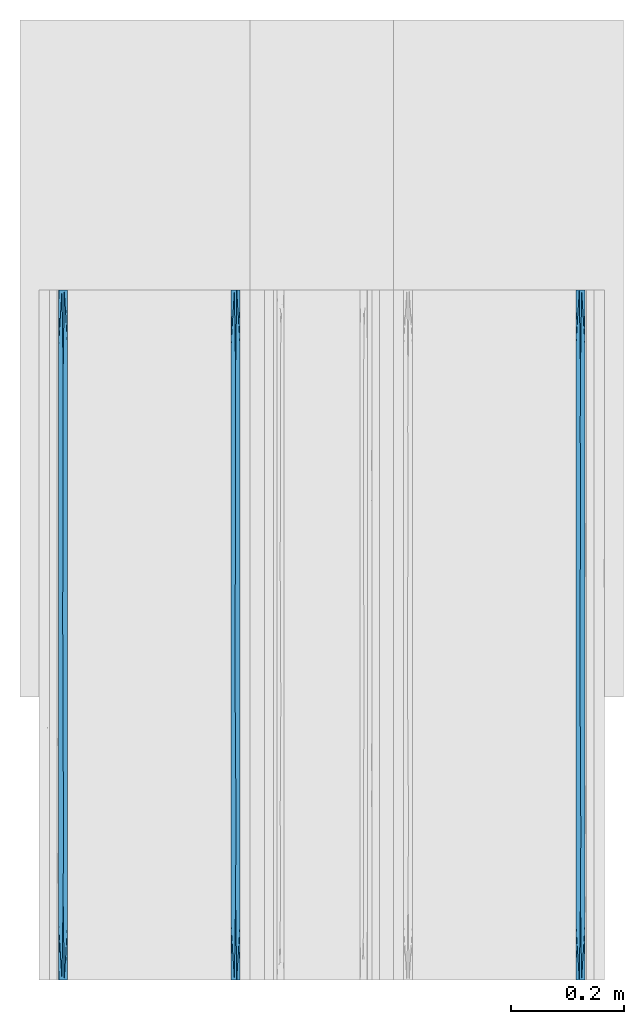
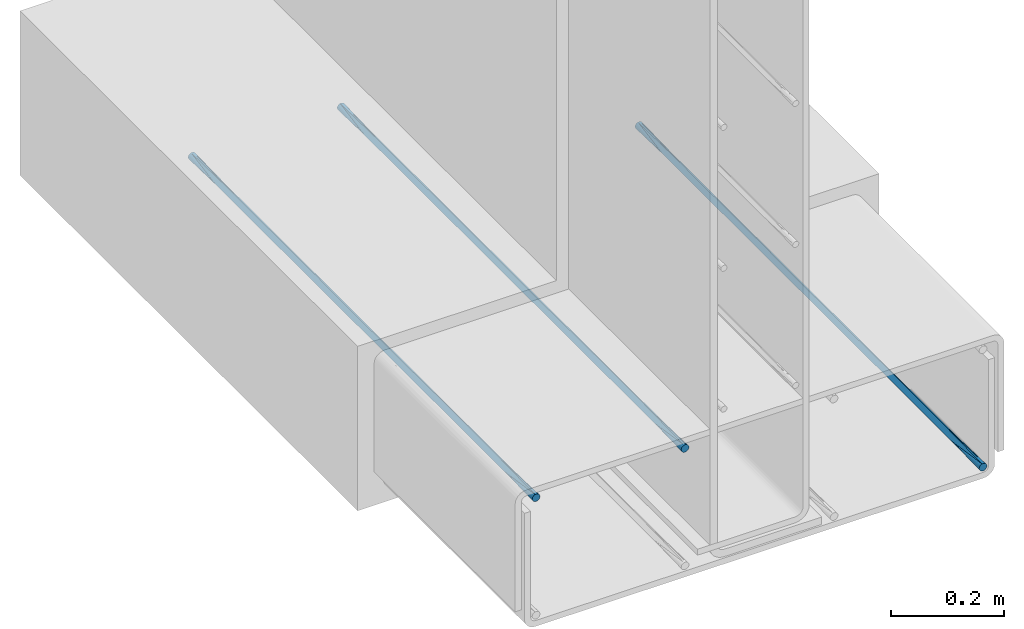
# One storey, part 6 of 10: 3 walls.
"""IFC2X3 building model written with IfcOpenShell, lengths in feet."""

from ifc_helpers import new_model, entity, si_unit, converted_unit, derived_unit, direction, frame, origin, place, context, subcontext, project, spatial, faceted_brep, material, type_object, element, save


model = new_model("IFC2X3")

# Units and contexts
model_context = context("Model", 3, precision=0.0001, world=origin(), true_north=direction((6.12303176911189e-17, 1.0)))
body_context = subcontext(model_context, "Body", "Model", "MODEL_VIEW")
ifc_project = project(units=[converted_unit("LENGTHUNIT", "FOOT", entity("IfcRatioMeasure", 0.3048), si_unit("LENGTHUNIT", "METRE"), dimensions=[1, 0, 0, 0, 0, 0, 0]), converted_unit("AREAUNIT", "SQUARE FOOT", entity("IfcRatioMeasure", 0.09290304), si_unit("AREAUNIT", "SQUARE_METRE"), dimensions=[2, 0, 0, 0, 0, 0, 0]), converted_unit("VOLUMEUNIT", "CUBIC FOOT", entity("IfcRatioMeasure", 0.028316846592), si_unit("VOLUMEUNIT", "CUBIC_METRE"), dimensions=[3, 0, 0, 0, 0, 0, 0]), converted_unit("PLANEANGLEUNIT", "DEGREE", entity("IfcRatioMeasure", 0.0174532925199433), si_unit("PLANEANGLEUNIT", "RADIAN"), dimensions=[0, 0, 0, 0, 0, 0, 0]), si_unit("MASSUNIT", "GRAM", prefix="KILO"), derived_unit("MASSDENSITYUNIT", [(si_unit("MASSUNIT", "GRAM", prefix="KILO"), 1), (si_unit("LENGTHUNIT", "METRE"), -3)]), si_unit("TIMEUNIT", "SECOND"), si_unit("FREQUENCYUNIT", "HERTZ"), si_unit("THERMODYNAMICTEMPERATUREUNIT", "DEGREE_CELSIUS"), derived_unit("THERMALTRANSMITTANCEUNIT", [(si_unit("MASSUNIT", "GRAM", prefix="KILO"), 1), (si_unit("THERMODYNAMICTEMPERATUREUNIT", "KELVIN"), -1), (si_unit("TIMEUNIT", "SECOND"), -3)]), derived_unit("VOLUMETRICFLOWRATEUNIT", [(si_unit("LENGTHUNIT", "METRE"), 3), (si_unit("TIMEUNIT", "SECOND"), -1)]), si_unit("ELECTRICCURRENTUNIT", "AMPERE"), si_unit("ELECTRICVOLTAGEUNIT", "VOLT"), si_unit("POWERUNIT", "WATT"), si_unit("FORCEUNIT", "NEWTON", prefix="KILO"), si_unit("ILLUMINANCEUNIT", "LUX"), si_unit("LUMINOUSFLUXUNIT", "LUMEN"), si_unit("LUMINOUSINTENSITYUNIT", "CANDELA"), derived_unit("USERDEFINED", [(si_unit("MASSUNIT", "GRAM", prefix="KILO"), -1), (si_unit("LENGTHUNIT", "METRE"), -2), (si_unit("TIMEUNIT", "SECOND"), 3), (si_unit("LUMINOUSFLUXUNIT", "LUMEN"), 1)]), derived_unit("LINEARVELOCITYUNIT", [(si_unit("LENGTHUNIT", "METRE"), 1), (si_unit("TIMEUNIT", "SECOND"), -1)]), si_unit("PRESSUREUNIT", "PASCAL"), derived_unit("USERDEFINED", [(si_unit("LENGTHUNIT", "METRE"), -2), (si_unit("MASSUNIT", "GRAM", prefix="KILO"), 1), (si_unit("TIMEUNIT", "SECOND"), -2)])], contexts=[model_context])

# Site, building, storey
site_placement = place(None, origin())
site = spatial("IfcSite", under=ifc_project, at=site_placement, CompositionType="ELEMENT")
building_placement = place(site_placement, origin())
building = spatial("IfcBuilding", under=site, at=building_placement, CompositionType="ELEMENT")
storey_placement = place(building_placement, frame((0.0, 0.0, 11.2604166666667)))
storey = spatial("IfcBuildingStorey", under=building, at=storey_placement, Name="2ND FLOOR", CompositionType="ELEMENT", Elevation=11.2604166666667)

# Walls
ifc_material = material()
wall_type_1 = type_object("IfcWallType", Name="Generic Models 1", PredefinedType="NOTDEFINED", material=ifc_material)
wall_1_placement = place(storey_placement, frame((1431.15274703322, 0.249999999995824, 2.87899174408174), z_axis=(0.0, 0.0, 1.0), x_axis=(0.0, 1.0, 0.0)))
element("IfcWall", 1, at=wall_1_placement, inside=storey, type_object=wall_type_1, material=ifc_material, Name="Generic Models 272:Generic Models 1", ObjectType="Generic Models 272:Generic Models 1", context=body_context, shape_type="Brep", body=[
    faceted_brep([(4.0, -0.0130208333334849, 0.0034889217764551), (4.0, -0.00762742757342494, 0.0076274275732775), (4.0, -0.00348892177657945, 0.0130208333333464), (4.0, -0.000887348273863608, 0.0193015873671367), (4.0, 0.0, 0.0260416666666821), (4.0, -0.000887348273863608, 0.0327817459662274), (4.0, -0.00348892177657945, 0.0390625000000142), (4.0, -0.00762742757342494, 0.0444559057600777), (4.0, -0.0130208333334849, 0.0485944115568948), (4.0, -0.0193015873671811, 0.0511959850596142), (4.0, -0.0260416666667425, 0.0520833333333321), (4.0, -0.0327817459663038, 0.0511959850596071), (4.0, -0.0390625, 0.048594411556877), (4.0, -0.04445590576006, 0.0444559057600546), (4.0, -0.0485944115569055, 0.0390624999999858), (4.0, -0.0511959850596213, 0.0327817459661954), (4.0, -0.0520833333334849, 0.0260416666666501), (4.0, -0.0511959850596213, 0.0193015873671047), (4.0, -0.0485944115569055, 0.0130208333333179), (4.0, -0.04445590576006, 0.00762742757325441), (4.0, -0.0390625, 0.00348892177643734), (4.0, -0.0327817459663038, 0.000887348273717947), (4.0, -0.0260416666667425, 0.0), (4.0, -0.0193015873671811, 0.000887348273725053), (0.0, -0.0260416666667425, 0.0520833333333393), (0.0, -0.0193015873671811, 0.0511959850596213), (0.0, -0.0130208333334849, 0.0485944115569019), (0.0, -0.00762742757342494, 0.0444559057600848), (0.0, -0.00348892177657945, 0.0390625000000213), (0.0, -0.000887348273863608, 0.0327817459662345), (0.0, 0.0, 0.0260416666666892), (0.0, -0.000887348273863608, 0.0193015873671438), (0.0, -0.00348892177657945, 0.0130208333333535), (0.0, -0.00762742757342494, 0.00762742757328461), (0.0, -0.0130208333334849, 0.00348892177646221), (0.0, -0.0193015873671811, 0.000887348273732158), (0.0, -0.0260416666667425, 0.0), (0.0, -0.0327817459663038, 0.000887348273725053), (0.0, -0.0390625, 0.00348892177644444), (0.0, -0.04445590576006, 0.00762742757326151), (0.0, -0.0485944115569055, 0.013020833333325), (0.0, -0.0511959850596213, 0.0193015873671119), (0.0, -0.0520833333334849, 0.0260416666666572), (0.0, -0.0511959850596213, 0.0327817459662025), (0.0, -0.0485944115569055, 0.0390624999999929), (0.0, -0.04445590576006, 0.0444559057600618), (0.0, -0.0390625, 0.0485944115568842), (0.0, -0.0327817459663038, 0.0511959850596142), (3.67725138549306, 0.0, 0.0260416666666821), (0.32274862547415, -0.0520833333334849, 0.0260416666666572), (3.67725140296933, -0.0520833333334849, 0.0260416666666501), (3.51587705267192, -0.0260416670323593, 0.0), (2.87037982919681, -0.0260416666374113, 0.0), (2.52958652603254, -0.026227183774381, 6.60807051744428e-07), (2.70900554197223, 0.0, 0.0260416666666838), (2.70900552654688, -0.0520833333334849, 0.0260416666666519), (1.90213399266994, -0.0280271573828941, 7.58000453888741e-05), (1.5, 0.0, 0.0260416666666874), (1.74075971428411, 0.0, 0.0260416666666874), (2.0, 0.0, 0.0260416666666856), (1.58481828942483, -0.0281065462752395, 8.19926513742075e-05), (2.35450277098611, 0.0, 0.0260416666666838), (2.38625689346174, 0.0, 0.0260416666666874), (0.322748614506943, 0.0, 0.0260416666666892), (0.484122917594275, -0.0260416666644687, 0.0), (0.645497229013885, 0.0, 0.0260416666666874), (3.03175415647917, 0.0, 0.0260416666666838), (3.35450277098611, 0.0, 0.0260416666666838), (0.802626606099821, -0.0241210785507064, 7.09188132521632e-05), (1.0, 0.0, 0.0260416666666874), (1.12499999124347, -0.0246126796300814, 3.92360336185504e-05), (3.35450277749518, -0.0520833333334849, 0.0260416666666519), (2.2160433903769, -0.0283845183157609, 0.000105602028249052), (2.06350830404206, -0.0520833333334849, 0.0260416666666519), (2.00000002040847, -0.0520833333334849, 0.0260416666666536), (1.74075970701139, -0.0520833333334849, 0.0260416666666536), (3.19312844079874, -0.0276322430397613, 4.86201045735157e-05), (3.03175415202103, -0.0520833333334849, 0.0260416666666519), (0.70900554076862, -0.0520833333334849, 0.0260416666666554), (0.645497257127644, -0.0520833333334849, 0.0260416666666554), (1.41801108153724, -0.0520833333334849, 0.0260416666666554), (1.25, 0.0, 0.0260416666666874), (1.41801107183056, 0.0, 0.0260416666666874), (2.38625690107273, -0.0520833333334849, 0.0260416666666554), (2.06350830387292, 0.0, 0.0260416666666856), (1.50000002551058, -0.0520833333334849, 0.0260416666666536), (1.25000002806164, -0.0520833333334849, 0.0260416666666554), (1.06350832537467, -0.0520833333334849, 0.0260416666666554), (1.06350827744056, 0.0, 0.0260416666666874), (1.0000000306127, -0.0520833333334849, 0.0260416666666554), (2.35450279389352, -0.0520833333334849, 0.0260416666666536), (0.70900553591528, 0.0, 0.0260416666666874), (1.90213399388276, -0.0240561759483171, 0.0520075332877745), (3.51587705385881, -0.0260416658200029, 0.0520833333333339), (2.87037983051048, -0.0260416667615573, 0.0520833333333339), (2.52958652644354, -0.0258561495911636, 0.0520826725265131), (0.484122917756005, -0.0260416666742458, 0.0520833333333393), (3.19312844116365, -0.0244510900004116, 0.0520347132108157), (1.58481829017475, -0.023976787102356, 0.0520013406854787), (1.12499999099503, -0.0274706537484235, 0.052044097297248), (0.802626606321884, -0.0279622548152929, 0.0520124145176908), (2.2160433912069, -0.023698814974523, 0.051977731301184)], [[[0, 1, 2, 3, 4, 5, 6, 7, 8, 9, 10, 11, 12, 13, 14, 15, 16, 17, 18, 19, 20, 21, 22, 23]], [[24, 25, 26, 27, 28, 29, 30, 31, 32, 33, 34, 35, 36, 37, 38, 39, 40, 41, 42, 43, 44, 45, 46, 47]], [[2, 48, 3]], [[49, 42, 41]], [[17, 16, 50]], [[20, 50, 21]], [[50, 51, 21]], [[40, 49, 41]], [[52, 53, 54]], [[52, 55, 53]], [[50, 19, 18]], [[56, 57, 58, 59]], [[38, 37, 49]], [[60, 57, 56]], [[0, 48, 1]], [[53, 61, 62, 54]], [[63, 32, 31]], [[64, 63, 65]], [[52, 54, 66]], [[48, 51, 67]], [[68, 69, 70]], [[23, 22, 51]], [[35, 64, 36]], [[2, 1, 48]], [[18, 17, 50]], [[19, 50, 20]], [[50, 71, 51]], [[56, 72, 73]], [[56, 73, 74, 75]], [[67, 51, 76]], [[55, 52, 77]], [[64, 78, 79, 49]], [[39, 38, 49]], [[0, 23, 48]], [[48, 23, 51]], [[60, 80, 70]], [[64, 65, 68]], [[37, 36, 64]], [[51, 22, 21]], [[60, 81, 82, 57]], [[40, 39, 49]], [[32, 63, 33]], [[77, 52, 76]], [[66, 67, 76]], [[34, 33, 63]], [[71, 77, 76]], [[35, 63, 64]], [[34, 63, 35]], [[48, 4, 3]], [[31, 30, 63]], [[53, 72, 61]], [[53, 83, 72]], [[64, 49, 37]], [[56, 75, 60]], [[72, 59, 84, 61]], [[60, 75, 85, 80]], [[70, 81, 60]], [[64, 68, 78]], [[70, 80, 86, 87]], [[70, 69, 88, 81]], [[68, 87, 89, 78]], [[72, 56, 59]], [[83, 53, 55]], [[72, 83, 90, 73]], [[76, 52, 66]], [[71, 76, 51]], [[68, 65, 91, 69]], [[87, 68, 70]], [[92, 84, 59, 58]], [[14, 50, 15]], [[8, 48, 9]], [[48, 93, 9]], [[28, 63, 29]], [[94, 95, 55]], [[44, 43, 49]], [[94, 54, 95]], [[47, 96, 24]], [[11, 10, 93]], [[5, 4, 48]], [[63, 30, 29]], [[66, 94, 97]], [[98, 85, 92]], [[12, 50, 13]], [[98, 86, 80, 85]], [[89, 99, 100]], [[49, 79, 96]], [[96, 91, 65, 63]], [[7, 48, 8]], [[48, 6, 5]], [[14, 13, 50]], [[48, 7, 6]], [[50, 93, 71]], [[48, 67, 93]], [[92, 101, 84]], [[12, 11, 50]], [[66, 54, 94]], [[95, 90, 83, 55]], [[27, 26, 63]], [[50, 11, 93]], [[96, 79, 100]], [[98, 82, 99]], [[92, 85, 75, 74]], [[24, 96, 25]], [[93, 10, 9]], [[97, 77, 71]], [[28, 27, 63]], [[44, 49, 45]], [[50, 16, 15]], [[43, 42, 49]], [[93, 97, 71]], [[46, 45, 49]], [[67, 66, 97]], [[47, 49, 96]], [[46, 49, 47]], [[26, 25, 63]], [[95, 101, 90]], [[95, 62, 101]], [[96, 63, 25]], [[92, 58, 98]], [[101, 74, 73, 90]], [[98, 58, 57, 82]], [[99, 86, 98]], [[96, 100, 91]], [[99, 82, 81, 88]], [[99, 89, 87, 86]], [[100, 88, 69, 91]], [[101, 92, 74]], [[94, 55, 77]], [[62, 95, 54]], [[101, 62, 61, 84]], [[97, 94, 77]], [[67, 97, 93]], [[100, 79, 78, 89]], [[88, 100, 99]]]),
])
wall_type_2 = type_object("IfcWallType", Name="Generic Models 1", PredefinedType="NOTDEFINED", material=ifc_material)
wall_2_placement = place(storey_placement, frame((1428.15274703322, 0.249999999995834, 3.71232507741509), z_axis=(0.0, 0.0, 1.0), x_axis=(0.0, 1.0, 0.0)))
element("IfcWall", 2, at=wall_2_placement, inside=storey, type_object=wall_type_2, material=ifc_material, Name="Generic Models 54:Generic Models 1", ObjectType="Generic Models 54:Generic Models 1", context=body_context, shape_type="Brep", body=[
    faceted_brep([(4.0, -0.0130208333334849, 0.0034889217764551), (4.0, -0.00762742757342494, 0.0076274275732775), (4.0, -0.00348892177657945, 0.0130208333333464), (4.0, -0.000887348273863608, 0.0193015873671367), (4.0, 0.0, 0.0260416666666821), (4.0, -0.000887348273863608, 0.0327817459662274), (4.0, -0.00348892177657945, 0.0390625000000142), (4.0, -0.00762742757342494, 0.0444559057600777), (4.0, -0.0130208333334849, 0.0485944115568948), (4.0, -0.0193015873671811, 0.0511959850596142), (4.0, -0.0260416666667425, 0.0520833333333321), (4.0, -0.0327817459663038, 0.0511959850596071), (4.0, -0.0390625, 0.048594411556877), (4.0, -0.04445590576006, 0.0444559057600546), (4.0, -0.0485944115569055, 0.0390624999999858), (4.0, -0.0511959850596213, 0.0327817459661954), (4.0, -0.0520833333334849, 0.0260416666666501), (4.0, -0.0511959850596213, 0.0193015873671047), (4.0, -0.0485944115569055, 0.0130208333333179), (4.0, -0.04445590576006, 0.00762742757325441), (4.0, -0.0390625, 0.00348892177643734), (4.0, -0.0327817459663038, 0.000887348273717947), (4.0, -0.0260416666667425, 0.0), (4.0, -0.0193015873671811, 0.000887348273725053), (0.0, -0.0260416666667425, 0.0520833333333393), (0.0, -0.0193015873671811, 0.0511959850596213), (0.0, -0.0130208333334849, 0.0485944115569019), (0.0, -0.00762742757342494, 0.0444559057600848), (0.0, -0.00348892177657945, 0.0390625000000213), (0.0, -0.000887348273863608, 0.0327817459662345), (0.0, 0.0, 0.0260416666666892), (0.0, -0.000887348273863608, 0.0193015873671438), (0.0, -0.00348892177657945, 0.0130208333333535), (0.0, -0.00762742757342494, 0.00762742757328461), (0.0, -0.0130208333334849, 0.00348892177646221), (0.0, -0.0193015873671811, 0.000887348273732158), (0.0, -0.0260416666667425, 0.0), (0.0, -0.0327817459663038, 0.000887348273725053), (0.0, -0.0390625, 0.00348892177644444), (0.0, -0.04445590576006, 0.00762742757326151), (0.0, -0.0485944115569055, 0.013020833333325), (0.0, -0.0511959850596213, 0.0193015873671119), (0.0, -0.0520833333334849, 0.0260416666666572), (0.0, -0.0511959850596213, 0.0327817459662025), (0.0, -0.0485944115569055, 0.0390624999999929), (0.0, -0.04445590576006, 0.0444559057600618), (0.0, -0.0390625, 0.0485944115568842), (0.0, -0.0327817459663038, 0.0511959850596142), (3.67725138549306, 0.0, 0.0260416666666821), (0.32274862547415, -0.0520833333334849, 0.0260416666666554), (3.67725140296933, -0.0520833333334849, 0.0260416666666501), (3.51587705267192, -0.0260416670323593, 0.0), (2.87037982919681, -0.0260416666374113, 0.0), (2.52958652603254, -0.026227183774381, 6.60807051744428e-07), (2.70900554197223, 0.0, 0.0260416666666838), (2.70900552654688, -0.0520833333334849, 0.0260416666666519), (1.90213399266994, -0.0280271573828941, 7.58000453888741e-05), (1.5, 0.0, 0.0260416666666874), (1.74075971428411, 0.0, 0.0260416666666874), (2.0, 0.0, 0.0260416666666856), (1.58481828942483, -0.0281065462752395, 8.19926513742075e-05), (2.35450277098611, 0.0, 0.0260416666666838), (2.38625689346174, 0.0, 0.0260416666666856), (0.322748614506943, 0.0, 0.0260416666666892), (0.484122917594275, -0.0260416666644687, 0.0), (0.645497229013885, 0.0, 0.0260416666666874), (3.03175415647917, 0.0, 0.0260416666666838), (3.35450277098611, 0.0, 0.0260416666666838), (0.802626606099821, -0.0241210785507064, 7.09188132521632e-05), (1.0, 0.0, 0.0260416666666874), (1.12499999124347, -0.0246126796300814, 3.92360336185504e-05), (3.35450277749518, -0.0520833333334849, 0.0260416666666501), (2.2160433903769, -0.0283845183157609, 0.000105602028249052), (2.06350830404206, -0.0520833333334849, 0.0260416666666536), (2.00000002040847, -0.0520833333334849, 0.0260416666666536), (1.74075970701139, -0.0520833333334849, 0.0260416666666536), (3.19312844079874, -0.0276322430397613, 4.86201045735157e-05), (3.03175415202103, -0.0520833333334849, 0.0260416666666519), (0.70900554076862, -0.0520833333334849, 0.0260416666666572), (0.645497257127644, -0.0520833333332575, 0.0260416666666554), (1.41801108153724, -0.0520833333334849, 0.0260416666666554), (1.25, 0.0, 0.0260416666666874), (1.41801107183056, 0.0, 0.0260416666666874), (2.38625690107273, -0.0520833333334849, 0.0260416666666554), (2.06350830387292, 0.0, 0.0260416666666856), (1.50000002551058, -0.0520833333334849, 0.0260416666666536), (1.25000002806164, -0.0520833333334849, 0.0260416666666554), (1.06350832537467, -0.0520833333334849, 0.0260416666666554), (1.06350827744056, 0.0, 0.0260416666666874), (1.0000000306127, -0.0520833333334849, 0.0260416666666554), (2.35450279389352, -0.0520833333334849, 0.0260416666666536), (0.70900553591528, 0.0, 0.0260416666666892), (1.90213399388276, -0.0240561759483171, 0.0520075332877745), (3.51587705385881, -0.0260416658200029, 0.0520833333333339), (2.87037983051048, -0.0260416667615573, 0.0520833333333339), (2.52958652644354, -0.0258561495911636, 0.0520826725265131), (0.484122917756005, -0.0260416666742458, 0.0520833333333393), (3.19312844116365, -0.0244510900004116, 0.0520347132108157), (1.58481829017475, -0.023976787102356, 0.0520013406854787), (1.12499999099503, -0.0274706537484235, 0.052044097297248), (0.802626606321884, -0.0279622548152929, 0.0520124145176908), (2.2160433912069, -0.023698814974523, 0.051977731301184)], [[[0, 1, 2, 3, 4, 5, 6, 7, 8, 9, 10, 11, 12, 13, 14, 15, 16, 17, 18, 19, 20, 21, 22, 23]], [[24, 25, 26, 27, 28, 29, 30, 31, 32, 33, 34, 35, 36, 37, 38, 39, 40, 41, 42, 43, 44, 45, 46, 47]], [[2, 48, 3]], [[49, 42, 41]], [[17, 16, 50]], [[20, 50, 21]], [[50, 51, 21]], [[40, 49, 41]], [[52, 53, 54]], [[52, 55, 53]], [[50, 19, 18]], [[56, 57, 58, 59]], [[38, 37, 49]], [[60, 57, 56]], [[0, 48, 1]], [[53, 61, 62, 54]], [[63, 32, 31]], [[64, 63, 65]], [[52, 54, 66]], [[48, 51, 67]], [[68, 69, 70]], [[23, 22, 51]], [[35, 64, 36]], [[2, 1, 48]], [[18, 17, 50]], [[19, 50, 20]], [[50, 71, 51]], [[56, 72, 73]], [[56, 73, 74, 75]], [[67, 51, 76]], [[55, 52, 77]], [[64, 78, 79, 49]], [[39, 38, 49]], [[0, 23, 48]], [[48, 23, 51]], [[60, 80, 70]], [[64, 65, 68]], [[37, 36, 64]], [[51, 22, 21]], [[60, 81, 82, 57]], [[40, 39, 49]], [[32, 63, 33]], [[77, 52, 76]], [[66, 67, 76]], [[34, 33, 63]], [[71, 77, 76]], [[35, 63, 64]], [[34, 63, 35]], [[48, 4, 3]], [[31, 30, 63]], [[53, 72, 61]], [[53, 83, 72]], [[64, 49, 37]], [[56, 75, 60]], [[72, 59, 84, 61]], [[60, 75, 85, 80]], [[70, 81, 60]], [[64, 68, 78]], [[70, 80, 86, 87]], [[70, 69, 88, 81]], [[68, 87, 89, 78]], [[72, 56, 59]], [[83, 53, 55]], [[72, 83, 90, 73]], [[76, 52, 66]], [[71, 76, 51]], [[68, 65, 91, 69]], [[87, 68, 70]], [[92, 84, 59, 58]], [[14, 50, 15]], [[8, 48, 9]], [[48, 93, 9]], [[28, 63, 29]], [[94, 95, 55]], [[44, 43, 49]], [[94, 54, 95]], [[47, 96, 24]], [[11, 10, 93]], [[5, 4, 48]], [[63, 30, 29]], [[66, 94, 97]], [[98, 85, 92]], [[12, 50, 13]], [[98, 86, 80, 85]], [[89, 99, 100]], [[49, 79, 96]], [[96, 91, 65, 63]], [[7, 48, 8]], [[48, 6, 5]], [[14, 13, 50]], [[48, 7, 6]], [[50, 93, 71]], [[48, 67, 93]], [[92, 101, 84]], [[12, 11, 50]], [[66, 54, 94]], [[95, 90, 83, 55]], [[27, 26, 63]], [[50, 11, 93]], [[96, 79, 100]], [[98, 82, 99]], [[92, 85, 75, 74]], [[24, 96, 25]], [[93, 10, 9]], [[97, 77, 71]], [[28, 27, 63]], [[44, 49, 45]], [[50, 16, 15]], [[43, 42, 49]], [[93, 97, 71]], [[46, 45, 49]], [[67, 66, 97]], [[47, 49, 96]], [[46, 49, 47]], [[26, 25, 63]], [[95, 101, 90]], [[95, 62, 101]], [[96, 63, 25]], [[92, 58, 98]], [[101, 74, 73, 90]], [[98, 58, 57, 82]], [[99, 86, 98]], [[96, 100, 91]], [[99, 82, 81, 88]], [[99, 89, 87, 86]], [[100, 88, 69, 91]], [[101, 92, 74]], [[94, 55, 77]], [[62, 95, 54]], [[101, 62, 61, 84]], [[97, 94, 77]], [[67, 97, 93]], [[100, 79, 78, 89]], [[88, 100, 99]]]),
])
wall_type_3 = type_object("IfcWallType", Name="Generic Models 1", PredefinedType="NOTDEFINED", material=ifc_material)
wall_3_placement = place(storey_placement, frame((1429.15274703322, 0.24999999999583, 3.71232507741509), z_axis=(0.0, 0.0, 1.0), x_axis=(0.0, 1.0, 0.0)))
element("IfcWall", 3, at=wall_3_placement, inside=storey, type_object=wall_type_3, material=ifc_material, Name="Generic Models 67:Generic Models 1", ObjectType="Generic Models 67:Generic Models 1", context=body_context, shape_type="Brep", body=[
    faceted_brep([(4.0, -0.0130208333334849, 0.0034889217764551), (4.0, -0.00762742757342494, 0.0076274275732775), (4.0, -0.00348892177657945, 0.0130208333333464), (4.0, -0.000887348273863608, 0.0193015873671367), (4.0, 0.0, 0.0260416666666821), (4.0, -0.000887348273863608, 0.0327817459662274), (4.0, -0.00348892177657945, 0.0390625000000142), (4.0, -0.00762742757342494, 0.0444559057600777), (4.0, -0.0130208333334849, 0.0485944115568948), (4.0, -0.0193015873671811, 0.0511959850596142), (4.0, -0.0260416666667425, 0.0520833333333321), (4.0, -0.0327817459663038, 0.0511959850596071), (4.0, -0.0390625, 0.048594411556877), (4.0, -0.04445590576006, 0.0444559057600546), (4.0, -0.0485944115569055, 0.0390624999999858), (4.0, -0.0511959850596213, 0.0327817459661954), (4.0, -0.0520833333334849, 0.0260416666666501), (4.0, -0.0511959850596213, 0.0193015873671047), (4.0, -0.0485944115569055, 0.0130208333333179), (4.0, -0.04445590576006, 0.00762742757325441), (4.0, -0.0390625, 0.00348892177643734), (4.0, -0.0327817459663038, 0.000887348273717947), (4.0, -0.0260416666667425, 0.0), (4.0, -0.0193015873671811, 0.000887348273725053), (0.0, -0.0260416666667425, 0.0520833333333393), (0.0, -0.0193015873671811, 0.0511959850596213), (0.0, -0.0130208333334849, 0.0485944115569019), (0.0, -0.00762742757342494, 0.0444559057600848), (0.0, -0.00348892177657945, 0.0390625000000213), (0.0, -0.000887348273863608, 0.0327817459662345), (0.0, 0.0, 0.0260416666666892), (0.0, -0.000887348273863608, 0.0193015873671438), (0.0, -0.00348892177657945, 0.0130208333333535), (0.0, -0.00762742757342494, 0.00762742757328461), (0.0, -0.0130208333334849, 0.00348892177646221), (0.0, -0.0193015873671811, 0.000887348273732158), (0.0, -0.0260416666667425, 0.0), (0.0, -0.0327817459663038, 0.000887348273725053), (0.0, -0.0390625, 0.00348892177644444), (0.0, -0.04445590576006, 0.00762742757326151), (0.0, -0.0485944115569055, 0.013020833333325), (0.0, -0.0511959850596213, 0.0193015873671119), (0.0, -0.0520833333334849, 0.0260416666666572), (0.0, -0.0511959850596213, 0.0327817459662025), (0.0, -0.0485944115569055, 0.0390624999999929), (0.0, -0.04445590576006, 0.0444559057600618), (0.0, -0.0390625, 0.0485944115568842), (0.0, -0.0327817459663038, 0.0511959850596142), (3.67725138549306, 0.0, 0.0260416666666821), (0.32274862547415, -0.0520833333334849, 0.0260416666666572), (3.67725140296933, -0.0520833333332575, 0.0260416666666501), (3.51587705267192, -0.0260416670323593, 0.0), (2.87037982919681, -0.0260416666374113, 0.0), (2.52958652603254, -0.026227183774381, 6.60807051744428e-07), (2.70900554197223, 0.0, 0.0260416666666838), (2.70900552654688, -0.0520833333334849, 0.0260416666666536), (1.90213399266994, -0.0280271573828941, 7.58000453888741e-05), (1.5, 0.0, 0.0260416666666874), (1.74075971428411, 0.0, 0.0260416666666856), (2.0, 0.0, 0.0260416666666856), (1.58481828942483, -0.0281065462752395, 8.19926513742075e-05), (2.35450277098611, 0.0, 0.0260416666666838), (2.38625689346174, 0.0, 0.0260416666666874), (0.322748614506943, 0.0, 0.0260416666666892), (0.484122917594275, -0.0260416666644687, 0.0), (0.645497229013885, 0.0, 0.0260416666666874), (3.03175415647917, 0.0, 0.0260416666666838), (3.35450277098611, 0.0, 0.0260416666666838), (0.802626606099821, -0.0241210785507064, 7.09188132521632e-05), (1.0, 0.0, 0.0260416666666874), (1.12499999124347, -0.0246126796300814, 3.92360336185504e-05), (3.35450277749518, -0.0520833333334849, 0.0260416666666519), (2.2160433903769, -0.0283845183157609, 0.000105602028249052), (2.06350830404206, -0.0520833333334849, 0.0260416666666536), (2.00000002040847, -0.0520833333334849, 0.0260416666666536), (1.74075970701139, -0.0520833333334849, 0.0260416666666536), (3.19312844079874, -0.0276322430397613, 4.86201045735157e-05), (3.03175415202103, -0.0520833333334849, 0.0260416666666519), (0.70900554076862, -0.0520833333334849, 0.0260416666666554), (0.645497257127644, -0.0520833333334849, 0.0260416666666554), (1.41801108153724, -0.0520833333334849, 0.0260416666666554), (1.25, 0.0, 0.0260416666666874), (1.41801107183056, 0.0, 0.0260416666666874), (2.38625690107273, -0.0520833333334849, 0.0260416666666519), (2.06350830387292, 0.0, 0.0260416666666856), (1.50000002551058, -0.0520833333334849, 0.0260416666666519), (1.25000002806164, -0.0520833333334849, 0.0260416666666554), (1.06350832537467, -0.0520833333334849, 0.0260416666666554), (1.06350827744056, 0.0, 0.0260416666666874), (1.0000000306127, -0.0520833333334849, 0.0260416666666554), (2.35450279389352, -0.0520833333334849, 0.0260416666666519), (0.70900553591528, 0.0, 0.0260416666666874), (1.90213399388276, -0.0240561759483171, 0.0520075332877745), (3.51587705385881, -0.0260416658200029, 0.0520833333333339), (2.87037983051048, -0.0260416667615573, 0.0520833333333339), (2.52958652644354, -0.0258561495911636, 0.0520826725265131), (0.484122917756005, -0.0260416666742458, 0.0520833333333393), (3.19312844116365, -0.0244510900004116, 0.0520347132108157), (1.58481829017475, -0.023976787102356, 0.0520013406854787), (1.12499999099503, -0.0274706537484235, 0.052044097297248), (0.802626606321884, -0.0279622548152929, 0.0520124145176908), (2.2160433912069, -0.023698814974523, 0.051977731301184)], [[[0, 1, 2, 3, 4, 5, 6, 7, 8, 9, 10, 11, 12, 13, 14, 15, 16, 17, 18, 19, 20, 21, 22, 23]], [[24, 25, 26, 27, 28, 29, 30, 31, 32, 33, 34, 35, 36, 37, 38, 39, 40, 41, 42, 43, 44, 45, 46, 47]], [[2, 48, 3]], [[49, 42, 41]], [[17, 16, 50]], [[20, 50, 21]], [[50, 51, 21]], [[40, 49, 41]], [[52, 53, 54]], [[52, 55, 53]], [[50, 19, 18]], [[56, 57, 58, 59]], [[38, 37, 49]], [[60, 57, 56]], [[0, 48, 1]], [[53, 61, 62, 54]], [[63, 32, 31]], [[64, 63, 65]], [[52, 54, 66]], [[48, 51, 67]], [[68, 69, 70]], [[23, 22, 51]], [[35, 64, 36]], [[2, 1, 48]], [[18, 17, 50]], [[19, 50, 20]], [[50, 71, 51]], [[56, 72, 73]], [[56, 73, 74, 75]], [[67, 51, 76]], [[55, 52, 77]], [[64, 78, 79, 49]], [[39, 38, 49]], [[0, 23, 48]], [[48, 23, 51]], [[60, 80, 70]], [[64, 65, 68]], [[37, 36, 64]], [[51, 22, 21]], [[60, 81, 82, 57]], [[40, 39, 49]], [[32, 63, 33]], [[77, 52, 76]], [[66, 67, 76]], [[34, 33, 63]], [[71, 77, 76]], [[35, 63, 64]], [[34, 63, 35]], [[48, 4, 3]], [[31, 30, 63]], [[53, 72, 61]], [[53, 83, 72]], [[64, 49, 37]], [[56, 75, 60]], [[72, 59, 84, 61]], [[60, 75, 85, 80]], [[70, 81, 60]], [[64, 68, 78]], [[70, 80, 86, 87]], [[70, 69, 88, 81]], [[68, 87, 89, 78]], [[72, 56, 59]], [[83, 53, 55]], [[72, 83, 90, 73]], [[76, 52, 66]], [[71, 76, 51]], [[68, 65, 91, 69]], [[87, 68, 70]], [[92, 84, 59, 58]], [[14, 50, 15]], [[8, 48, 9]], [[48, 93, 9]], [[28, 63, 29]], [[94, 95, 55]], [[44, 43, 49]], [[94, 54, 95]], [[47, 96, 24]], [[11, 10, 93]], [[5, 4, 48]], [[63, 30, 29]], [[66, 94, 97]], [[98, 85, 92]], [[12, 50, 13]], [[98, 86, 80, 85]], [[89, 99, 100]], [[49, 79, 96]], [[96, 91, 65, 63]], [[7, 48, 8]], [[48, 6, 5]], [[14, 13, 50]], [[48, 7, 6]], [[50, 93, 71]], [[48, 67, 93]], [[92, 101, 84]], [[12, 11, 50]], [[66, 54, 94]], [[95, 90, 83, 55]], [[27, 26, 63]], [[50, 11, 93]], [[96, 79, 100]], [[98, 82, 99]], [[92, 85, 75, 74]], [[24, 96, 25]], [[93, 10, 9]], [[97, 77, 71]], [[28, 27, 63]], [[44, 49, 45]], [[50, 16, 15]], [[43, 42, 49]], [[93, 97, 71]], [[46, 45, 49]], [[67, 66, 97]], [[47, 49, 96]], [[46, 49, 47]], [[26, 25, 63]], [[95, 101, 90]], [[95, 62, 101]], [[96, 63, 25]], [[92, 58, 98]], [[101, 74, 73, 90]], [[98, 58, 57, 82]], [[99, 86, 98]], [[96, 100, 91]], [[99, 82, 81, 88]], [[99, 89, 87, 86]], [[100, 88, 69, 91]], [[101, 92, 74]], [[94, 55, 77]], [[62, 95, 54]], [[101, 62, 61, 84]], [[97, 94, 77]], [[67, 97, 93]], [[100, 79, 78, 89]], [[88, 100, 99]]]),
])

save(model, "model.ifc")
